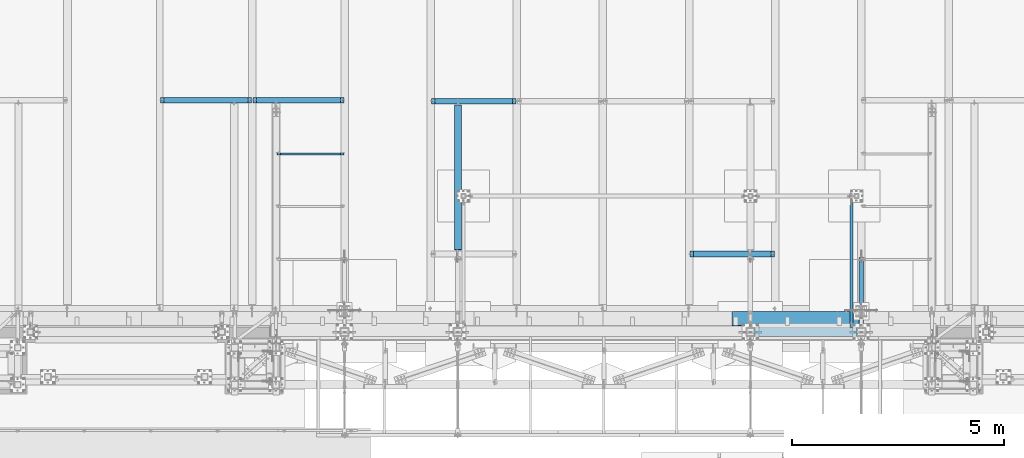
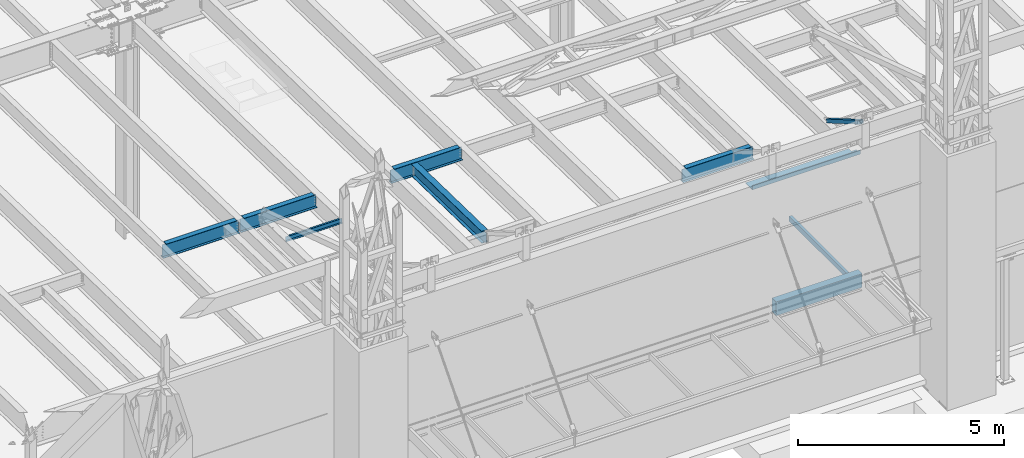
# One storey, part 1058 of 1763: 9 beams, 1 member, 10 elements without a shape of their own.
"""IFC2X3 building model written with IfcOpenShell, lengths in millimetres."""

from ifc_helpers import new_model, si_unit, frame, origin_with_axes, place, context, subcontext, project, spatial, faceted_brep, material, type_object, element, aggregate, save


model = new_model("IFC2X3")

# Units and contexts
model_context = context("Model", 3, precision=1e-05, world=origin_with_axes())
body_context = subcontext(model_context, "Body", "Model", "MODEL_VIEW")
ifc_project = project(units=[si_unit("LENGTHUNIT", "METRE", prefix="MILLI"), si_unit("AREAUNIT", "SQUARE_METRE"), si_unit("VOLUMEUNIT", "CUBIC_METRE"), si_unit("MASSUNIT", "GRAM", prefix="KILO"), si_unit("TIMEUNIT", "SECOND"), si_unit("PLANEANGLEUNIT", "RADIAN"), si_unit("SOLIDANGLEUNIT", "STERADIAN"), si_unit("THERMODYNAMICTEMPERATUREUNIT", "DEGREE_CELSIUS"), si_unit("LUMINOUSINTENSITYUNIT", "LUMEN")], contexts=[model_context])

# Site, building, storey
site_placement = place(None, origin_with_axes())
site = spatial("IfcSite", under=ifc_project, at=site_placement, CompositionType="ELEMENT")
building_placement = place(site_placement, origin_with_axes())
building = spatial("IfcBuilding", under=site, at=building_placement, Name="Undefined", CompositionType="ELEMENT")
storey_placement = place(building_placement, origin_with_axes())
storey = spatial("IfcBuildingStorey", under=building, at=storey_placement, Name="Undefined", CompositionType="ELEMENT", Elevation=0.0)

# Assembly, beam
assembly_1_placement = place(storey_placement, origin_with_axes())
assembly_1 = element("IfcElementAssembly", 1, at=assembly_1_placement, inside=storey, Name="CHANNEL", AssemblyPlace="NOTDEFINED", PredefinedType="RIGID_FRAME")
ifc_material_1 = material(Name="STEEL/A36")
beam_type_1 = type_object("IfcBeamType", Name="C6X8.2", PredefinedType="NOTDEFINED")
beam_1_placement = place(assembly_1_placement, frame((-63211.0608225783, -10007.1940204662, 12050.4660879227), z_axis=(0.0, 0.0, 1.0), x_axis=(1.0, 0.0, 0.0)))
beam_1 = element("IfcBeam", 2, at=beam_1_placement, type_object=beam_type_1, material=ifc_material_1, Name="CHANNEL", ObjectType="C6X8.2", context=body_context, shape_type="Brep", body=[
    faceted_brep([(94.4562501907349, 19.0499999999993, 50.7999999979074), (94.4562501907349, 23.8125, 50.7999999979074), (18.2562500000058, 23.8125, 50.7999999979074), (18.2562500000058, 19.0499999999993, 50.7999999979074), (99.3163297087813, 19.0499999999993, 51.766729920495), (99.3163297087813, 23.8125, 51.766729920495), (103.436506176935, 19.0499999999993, 54.5197438209725), (103.436506176935, 23.8125, 54.5197438209725), (106.189520077409, 19.0499999999993, 58.6399202891262), (106.189520077409, 23.8125, 58.6399202891262), (107.15625, 19.0499999999993, 63.4999998071726), (107.15625, 23.8125, 63.4999998071726), (107.15625, -23.8125, 76.2000000000007), (107.15625, 23.8125, 76.2000000000007), (107.15625, 19.0499999999993, 65.0887700000003), (107.15625, -23.8125, 72.2296624999999), (18.2562500000058, 19.0499999999993, -65.0887700000003), (18.2562500000058, -23.8125, -72.2296624999999), (1599.16104887993, -23.8125, -72.2296624999999), (1599.16104887993, 19.0499999999993, -65.0887700000003), (18.2562500000058, -23.8125, -76.2000000000007), (1599.16104887993, -23.8125, -76.2000000000007), (18.2562500000058, 23.8125, -76.2000000000007), (1599.16104887993, 23.8125, -76.2000000000007), (1599.16104887993, 23.8125, 50.8000000015836), (1599.16104887993, 19.0499999999993, 50.8000000015836), (1529.31104868917, 23.8125, 50.8000000015836), (1529.31104868917, 19.0499999999993, 50.8000000015836), (1524.45096917113, 23.8125, 51.7667299241712), (1524.45096917113, 19.0499999999993, 51.7667299241712), (1520.33079270297, 23.8125, 54.5197438246487), (1520.33079270297, 19.0499999999993, 54.5197438246487), (1517.5777788025, 23.8125, 58.6399202928023), (1517.5777788025, 19.0499999999993, 58.6399202928023), (1516.61104887991, 23.8125, 63.4999998108487), (1516.61104887991, 19.0499999999993, 63.4999998108487), (1516.61104887991, -23.8125, 76.2000000000007), (1516.61104887991, -23.8125, 72.2296624999999), (1516.61104887991, 19.0499999999993, 65.0887700000003), (1516.61104887991, 23.8125, 76.2000000000007)], [[[0, 1, 2, 3]], [[4, 5, 1, 0]], [[6, 7, 5, 4]], [[8, 9, 7, 6]], [[10, 11, 9, 8]], [[12, 13, 11, 10, 14, 15]], [[16, 17, 18, 19]], [[17, 20, 21, 18]], [[20, 22, 23, 21]], [[19, 18, 21, 23, 24, 25]], [[25, 24, 26, 27]], [[27, 26, 28, 29]], [[29, 28, 30, 31]], [[31, 30, 32, 33]], [[33, 32, 34, 35]], [[36, 37, 38, 35, 34, 39]], [[37, 36, 12, 15]], [[38, 37, 15, 14]], [[8, 6, 4, 0, 3, 16, 19, 25, 27, 29, 31, 33, 35, 38, 14, 10]], [[22, 20, 17, 16, 3, 2]], [[39, 34, 32, 30, 28, 26, 24, 23, 22, 2, 1, 5, 7, 9, 11, 13]], [[36, 39, 13, 12]]]),
])
aggregate(assembly_1, [beam_1])

assembly_2_placement = place(storey_placement, origin_with_axes())
assembly_2 = element("IfcElementAssembly", 3, at=assembly_2_placement, inside=storey, Name="BEAM", AssemblyPlace="NOTDEFINED", PredefinedType="RIGID_FRAME")
ifc_material_2 = material()
beam_type_2 = type_object("IfcBeamType", Name="HSS16X8X1/4", PredefinedType="NOTDEFINED")
beam_2_placement = place(assembly_2_placement, frame((-51917.027008321, -14208.1275869816, 8636.0), z_axis=(0.0, 0.0, 1.0), x_axis=(1.0, 0.0, 0.0)))
beam_2 = element("IfcBeam", 4, at=beam_2_placement, type_object=beam_type_2, material=ifc_material_2, Name="BEAM", ObjectType="HSS16X8X1/4", context=body_context, shape_type="Brep", body=[
    faceted_brep([(0.0, 95.25, -196.85), (0.0, -95.25, -196.85), (2413.00000000001, -95.25, -196.85), (2413.00000000001, 95.25, -196.85), (0.0, -95.25, 196.85), (2413.00000000001, -95.25, 196.85), (0.0, 95.25, 196.85), (2413.00000000001, 95.25, 196.85), (0.0, 101.600000000006, -203.2), (0.0, 101.600000000006, 203.2), (2413.00000000001, 101.6, 203.200000000001), (2413.00000000001, 101.6, -203.200000000001), (0.0, -101.600000000006, 203.2), (2413.00000000001, -101.6, 203.200000000001), (0.0, -101.600000000006, -203.2), (2413.00000000001, -101.6, -203.200000000001)], [[[0, 1, 2, 3]], [[1, 4, 5, 2]], [[4, 6, 7, 5]], [[6, 0, 3, 7]], [[8, 9, 10, 11]], [[9, 12, 13, 10]], [[12, 14, 15, 13]], [[14, 8, 11, 15]], [[13, 15, 11, 10], [5, 7, 3, 2]], [[14, 12, 9, 8], [6, 4, 1, 0]]]),
])
aggregate(assembly_2, [beam_2])

assembly_3_placement = place(storey_placement, origin_with_axes())
assembly_3 = element("IfcElementAssembly", 5, at=assembly_3_placement, inside=storey, Name="BEAM", AssemblyPlace="NOTDEFINED", PredefinedType="RIGID_FRAME")
ifc_material_3 = material(Name="STEEL/A992")
beam_type_3 = type_object("IfcBeamType", Name="W14X30", PredefinedType="NOTDEFINED")
beam_3_placement = place(assembly_3_placement, frame((-58917.9122752341, -12375.797568249, 12000.4308275564), z_axis=(0.0, 0.0209013539966291, 0.999781542838788), x_axis=(0.0, 0.999781542776098, -0.0209013569953182)))
beam_3 = element("IfcBeam", 6, at=beam_3_placement, type_object=beam_type_3, material=ifc_material_3, Name="BEAM", ObjectType="W14X30", context=body_context, shape_type="Brep", body=[
    faceted_brep([(3499.73692840905, -3.17500000000291, -166.687500001286), (3499.73692840905, -85.7249999999985, -166.687500001286), (3499.73692840905, -85.7249999999985, -176.212500001295), (3499.73692840905, 85.7249999999985, -176.212500001295), (3499.73692840905, 85.7249999999985, -166.687500001286), (3499.73692840905, 3.17500000000291, -166.687500001286), (3499.73692840906, 3.17500000000291, -163.51249981689), (3499.73692840906, -3.17500000000291, -163.51249981689), (3500.70365833165, 3.17500000000291, -158.652420298831), (3500.70365833165, -3.17500000000291, -158.652420298831), (3503.45667223214, 3.17500000000291, -154.532243830672), (3503.45667223214, -3.17500000000291, -154.532243830672), (3507.5768487003, 3.17500000000291, -151.779229930187), (3507.5768487003, -3.17500000000291, -151.779229930187), (3512.43692821836, 3.17500000000291, -150.812500007598), (3512.43692821836, -3.17500000000291, -150.812500007598), (3600.80591795297, -3.17500000000291, -150.812500007625), (3600.80591795297, 3.17500000000291, -150.812500007625), (111.128437087651, 3.17500000000291, 166.687500000098), (111.128437087651, 85.7249999999985, 166.687500000098), (3525.13692840938, 85.7249999999985, 166.687499998974), (3525.13692840938, 3.17500000000291, 166.687499998974), (111.128437087542, -3.17500000000291, -163.512499809849), (111.128437087542, 3.17500000000291, -163.512499809849), (111.12843708754, 3.17500000000291, -166.687500000171), (111.12843708754, 85.7249999999985, -166.687500000171), (111.128437087536, 85.7249999999985, -176.212500000178), (111.128437087536, -85.7249999999985, -176.212500000178), (111.12843708754, -85.7249999999985, -166.687500000171), (111.12843708754, -3.17500000000291, -166.687500000171), (110.161707164953, -3.17500000000291, -158.65242029179), (110.161707164953, 3.17500000000291, -158.65242029179), (107.408693264468, -3.17500000000291, -154.532243823627), (107.408693264468, 3.17500000000291, -154.532243823627), (103.288516796305, -3.17500000000291, -151.779229923141), (103.288516796305, 3.17500000000291, -151.779229923141), (98.4284372782495, -3.17500000000291, -150.812500000549), (98.4284372782495, 3.17500000000291, -150.812500000549), (22.7151965710145, -3.17500000000291, -150.812500000524), (22.7151965710145, 3.17500000000291, -150.812500000524), (16.40944753248, -3.17500000000291, 150.812500000327), (16.40944753248, 3.17500000000291, 150.812500000327), (98.4284372783495, -3.17500000000291, 150.8125000003), (98.4284372783495, 3.17500000000291, 150.8125000003), (103.288516796405, -3.17500000000291, 151.779229922889), (103.288516796405, 3.17500000000291, 151.779229922889), (107.408693264571, -3.17500000000291, 154.532243823371), (107.408693264571, 3.17500000000291, 154.532243823371), (110.161707165056, -3.17500000000291, 158.652420291533), (110.161707165056, 3.17500000000291, 158.652420291533), (111.128437087647, -3.17500000000291, 163.512499809589), (111.128437087647, 3.17500000000291, 163.512499809589), (111.128437087651, -85.7249999999985, 176.212500000105), (111.128437087651, 85.7249999999985, 176.212500000105), (111.128437087651, -3.17500000000291, 166.687500000098), (111.128437087651, -85.7249999999985, 166.687500000098), (3525.13692840938, -3.17500000000291, 166.687499998974), (3525.13692840938, -85.7249999999985, 166.687499998974), (3525.13692840938, -85.7249999999985, 176.212499998981), (3525.13692840938, 85.7249999999985, 176.212499998981), (3525.13692840938, -3.17500000000291, 163.512499802697), (3525.13692840938, 3.17500000000291, 163.512499802697), (3526.10365833196, -3.17500000000291, 158.652420284639), (3526.10365833196, 3.17500000000291, 158.652420284639), (3528.85667223244, -3.17500000000291, 154.532243816475), (3528.85667223244, 3.17500000000291, 154.532243816475), (3532.97684870061, -3.17500000000291, 151.77922991599), (3532.97684870061, 3.17500000000291, 151.77922991599), (3537.83692821866, -3.17500000000291, 150.812499993397), (3537.83692821866, 3.17500000000291, 150.812499993397), (3594.50016891443, -3.17500000000291, 150.812499993381), (3594.50016891443, 3.17500000000291, 150.812499993381)], [[[0, 1, 2, 3, 4, 5, 6, 7]], [[7, 6, 8, 9]], [[9, 8, 10, 11]], [[11, 10, 12, 13]], [[13, 12, 14, 15]], [[16, 15, 14, 17]], [[18, 19, 20, 21]], [[22, 23, 24, 25, 26, 27, 28, 29]], [[30, 31, 23, 22]], [[32, 33, 31, 30]], [[34, 35, 33, 32]], [[36, 37, 35, 34]], [[38, 39, 37, 36]], [[40, 41, 39, 38]], [[42, 43, 41, 40]], [[44, 45, 43, 42]], [[46, 47, 45, 44]], [[48, 49, 47, 46]], [[50, 51, 49, 48]], [[52, 53, 19, 18, 51, 50, 54, 55]], [[55, 54, 56, 57]], [[52, 55, 57, 58]], [[53, 52, 58, 59]], [[19, 53, 59, 20]], [[58, 57, 56, 60, 61, 21, 20, 59]], [[62, 63, 61, 60]], [[64, 65, 63, 62]], [[66, 67, 65, 64]], [[68, 69, 67, 66]], [[70, 71, 69, 68]], [[71, 70, 16, 17]], [[12, 10, 8, 6, 5, 24, 23, 31, 33, 35, 37, 39, 41, 43, 45, 47, 49, 51, 18, 21, 61, 63, 65, 67, 69, 71, 17, 14]], [[25, 24, 5, 4]], [[26, 25, 4, 3]], [[27, 26, 3, 2]], [[28, 27, 2, 1]], [[29, 28, 1, 0]], [[70, 68, 66, 64, 62, 60, 56, 54, 50, 48, 46, 44, 42, 40, 38, 36, 34, 32, 30, 22, 29, 0, 7, 9, 11, 13, 15, 16]]]),
])
aggregate(assembly_3, [beam_3])

assembly_4_placement = place(storey_placement, origin_with_axes())
assembly_4 = element("IfcElementAssembly", 7, at=assembly_4_placement, inside=storey, Name="BEAM", AssemblyPlace="NOTDEFINED", PredefinedType="RIGID_FRAME")
beam_type_4 = type_object("IfcBeamType", Name="W16X26", PredefinedType="NOTDEFINED")
beam_4_placement = place(assembly_4_placement, frame((-59562.4372736983, -8763.05542596541, 11901.1291231283), z_axis=(0.0, 0.0, 1.0), x_axis=(1.0, 0.0, 0.0)))
beam_4 = element("IfcBeam", 8, at=beam_4_placement, type_object=beam_type_4, material=ifc_material_3, Name="BEAM", ObjectType="W16X26", context=body_context, shape_type="Brep", body=[
    faceted_brep([(87.312500190732, -3.17499999999927, 161.665001675578), (87.312500190732, 3.17499999999927, 161.665001675578), (17.4624999999942, 3.17499999999927, 161.665001675578), (17.4624999999942, -3.17499999999927, 161.665001675578), (92.1725797087784, -3.17499999999927, 162.631731598165), (92.1725797087784, 3.17499999999927, 162.631731598165), (96.292756176932, -3.17499999999927, 165.384745498643), (96.292756176932, 3.17499999999927, 165.384745498643), (97.1527139056197, -3.17499999999927, 166.671763191049), (97.1527139056197, 3.17499999999927, 166.671763191049), (17.4625000000087, -3.17499999999927, -190.5), (17.4625000000087, -69.8500000000004, -190.5), (2014.53750000001, -69.8500000000004, -190.5), (2014.53750000001, -3.17499999999927, -190.5), (17.4625000000087, -69.8500000000004, -200.025), (2014.53750000001, -69.8500000000004, -200.025), (17.4625000000087, 69.8500000000004, -200.025), (2014.53750000001, 69.8500000000004, -200.025), (17.4625000000087, 69.8500000000004, -190.5), (2014.53750000001, 69.8500000000004, -190.5), (17.4625000000087, 3.17499999999927, -190.5), (2014.53750000001, 3.17499999999927, -190.5), (2014.53750000001, 3.17499999999927, 161.665001678701), (2014.53750000001, -3.17499999999927, 161.665001678701), (1944.68749980927, 3.17499999999927, 161.665001678701), (1944.68749980927, -3.17499999999927, 161.665001678701), (1939.82742029122, 3.17499999999927, 162.631731601288), (1939.82742029122, -3.17499999999927, 162.631731601288), (1935.70724382307, 3.17499999999927, 165.384745501766), (1935.70724382307, -3.17499999999927, 165.384745501766), (1934.84728609816, 3.17499999999927, 166.671763188517), (1934.84728609816, -3.17499999999927, 166.671763188517), (1934.11974687481, 3.17499999999927, 167.157889355802), (1934.11974687481, -3.17499999999927, 167.157889355802), (1931.36673297434, 3.17499999999927, 171.278065823955), (1931.36673297434, -3.17499999999927, 171.278065823955), (1930.40000305175, 3.17499999999927, 176.138145342002), (1930.40000305175, -3.17499999999927, 176.138145342002), (101.599996948236, 3.17499999999927, 190.5), (101.599996948236, 69.8500000000004, 190.5), (1930.40000305175, 69.8500000000004, 190.5), (1930.40000305175, 3.17499999999927, 190.5), (101.599996948236, -69.8500000000004, 200.025), (101.599996948236, -69.8500000000004, 190.5), (1930.40000305175, -69.8500000000004, 190.5), (1930.40000305175, -69.8500000000004, 200.025), (101.599996948236, 69.8500000000004, 200.025), (1930.40000305175, 69.8500000000004, 200.025), (1930.40000305175, -3.17499999999927, 190.5), (101.599996948236, -3.17499999999927, 190.5), (101.599996948236, 3.17499999999927, 176.138145342), (101.599996948236, -3.17499999999927, 176.138145342), (100.633267025645, 3.17499999999927, 171.278065823954), (100.633267025645, -3.17499999999927, 171.278065823954), (97.8802531251713, 3.17499999999927, 167.1578893558), (97.8802531251713, -3.17499999999927, 167.1578893558)], [[[0, 1, 2, 3]], [[4, 5, 1, 0]], [[6, 7, 5, 4]], [[8, 9, 7, 6]], [[10, 11, 12, 13]], [[11, 14, 15, 12]], [[14, 16, 17, 15]], [[16, 18, 19, 17]], [[18, 20, 21, 19]], [[13, 12, 15, 17, 19, 21, 22, 23]], [[23, 22, 24, 25]], [[25, 24, 26, 27]], [[27, 26, 28, 29]], [[29, 28, 30, 31]], [[32, 33, 31, 30]], [[33, 32, 34, 35]], [[35, 34, 36, 37]], [[38, 39, 40, 41]], [[42, 43, 44, 45]], [[46, 42, 45, 47]], [[39, 46, 47, 40]], [[45, 44, 48, 37, 36, 41, 40, 47]], [[43, 49, 48, 44]], [[42, 46, 39, 38, 50, 51, 49, 43]], [[51, 50, 52, 53]], [[53, 52, 54, 55]], [[4, 0, 3, 10, 13, 23, 25, 27, 29, 31, 33, 35, 37, 48, 49, 51, 53, 55, 8, 6]], [[20, 18, 16, 14, 11, 10, 3, 2]], [[54, 52, 50, 38, 41, 36, 34, 32, 30, 28, 26, 24, 22, 21, 20, 2, 1, 5, 7, 9]], [[55, 54, 9, 8]]]),
])
aggregate(assembly_4, [beam_4])

assembly_5_placement = place(storey_placement, origin_with_axes())
assembly_5 = element("IfcElementAssembly", 9, at=assembly_5_placement, inside=storey, Name="BEAM", AssemblyPlace="NOTDEFINED", PredefinedType="RIGID_FRAME")
beam_5_placement = place(assembly_5_placement, frame((-53466.4372736983, -12372.1144876504, 11976.5798333454), z_axis=(0.0, 0.0, 1.0), x_axis=(1.0, 0.0, 0.0)))
beam_5 = element("IfcBeam", 10, at=beam_5_placement, type_object=beam_type_4, material=ifc_material_3, Name="BEAM", ObjectType="W16X26", context=body_context, shape_type="Brep", body=[
    faceted_brep([(87.312500190732, -3.17499999999927, 161.665001675578), (87.312500190732, 3.17499999999927, 161.665001675578), (17.4624999999942, 3.17499999999927, 161.665001675578), (17.4624999999942, -3.17499999999927, 161.665001675578), (92.1725797087784, -3.17499999999927, 162.631731598165), (92.1725797087784, 3.17499999999927, 162.631731598165), (96.292756176932, -3.17499999999927, 165.384745498643), (96.292756176932, 3.17499999999927, 165.384745498643), (97.1527139056197, -3.17499999999927, 166.671763191049), (97.1527139056197, 3.17499999999927, 166.671763191049), (17.4625000000087, -3.17499999999927, -190.5), (17.4625000000087, -69.8500000000004, -190.5), (2014.53750000001, -69.8500000000004, -190.5), (2014.53750000001, -3.17499999999927, -190.5), (17.4625000000087, -69.8500000000004, -200.025), (2014.53750000001, -69.8500000000004, -200.025), (17.4625000000087, 69.8500000000004, -200.025), (2014.53750000001, 69.8500000000004, -200.025), (17.4625000000087, 69.8500000000004, -190.5), (2014.53750000001, 69.8500000000004, -190.5), (17.4625000000087, 3.17499999999927, -190.5), (2014.53750000001, 3.17499999999927, -190.5), (2014.53750000001, 3.17499999999927, 161.665001678701), (2014.53750000001, -3.17499999999927, 161.665001678701), (1944.68749980927, 3.17499999999927, 161.665001678701), (1944.68749980927, -3.17499999999927, 161.665001678701), (1939.82742029122, 3.17499999999927, 162.631731601288), (1939.82742029122, -3.17499999999927, 162.631731601288), (1935.70724382307, 3.17499999999927, 165.384745501766), (1935.70724382307, -3.17499999999927, 165.384745501766), (1934.84728609816, 3.17499999999927, 166.671763188517), (1934.84728609816, -3.17499999999927, 166.671763188517), (1934.11974687481, 3.17499999999927, 167.157889355802), (1934.11974687481, -3.17499999999927, 167.157889355802), (1931.36673297434, 3.17499999999927, 171.278065823955), (1931.36673297434, -3.17499999999927, 171.278065823955), (1930.40000305175, 3.17499999999927, 176.138145342002), (1930.40000305175, -3.17499999999927, 176.138145342002), (101.599996948236, 3.17499999999927, 190.5), (101.599996948236, 69.8500000000004, 190.5), (1930.40000305175, 69.8500000000004, 190.5), (1930.40000305175, 3.17499999999927, 190.5), (101.599996948236, -69.8500000000004, 200.025), (101.599996948236, -69.8500000000004, 190.5), (1930.40000305175, -69.8500000000004, 190.5), (1930.40000305175, -69.8500000000004, 200.025), (101.599996948236, 69.8500000000004, 200.025), (1930.40000305175, 69.8500000000004, 200.025), (1930.40000305175, -3.17499999999927, 190.5), (101.599996948236, -3.17499999999927, 190.5), (101.599996948236, 3.17499999999927, 176.138145342), (101.599996948236, -3.17499999999927, 176.138145342), (100.633267025645, 3.17499999999927, 171.278065823954), (100.633267025645, -3.17499999999927, 171.278065823954), (97.8802531251713, 3.17499999999927, 167.1578893558), (97.8802531251713, -3.17499999999927, 167.1578893558)], [[[0, 1, 2, 3]], [[4, 5, 1, 0]], [[6, 7, 5, 4]], [[8, 9, 7, 6]], [[10, 11, 12, 13]], [[11, 14, 15, 12]], [[14, 16, 17, 15]], [[16, 18, 19, 17]], [[18, 20, 21, 19]], [[13, 12, 15, 17, 19, 21, 22, 23]], [[23, 22, 24, 25]], [[25, 24, 26, 27]], [[27, 26, 28, 29]], [[29, 28, 30, 31]], [[32, 33, 31, 30]], [[33, 32, 34, 35]], [[35, 34, 36, 37]], [[38, 39, 40, 41]], [[42, 43, 44, 45]], [[46, 42, 45, 47]], [[39, 46, 47, 40]], [[45, 44, 48, 37, 36, 41, 40, 47]], [[43, 49, 48, 44]], [[42, 46, 39, 38, 50, 51, 49, 43]], [[51, 50, 52, 53]], [[53, 52, 54, 55]], [[4, 0, 3, 10, 13, 23, 25, 27, 29, 31, 33, 35, 37, 48, 49, 51, 53, 55, 8, 6]], [[20, 18, 16, 14, 11, 10, 3, 2]], [[54, 52, 50, 38, 41, 36, 34, 32, 30, 28, 26, 24, 22, 21, 20, 2, 1, 5, 7, 9]], [[55, 54, 9, 8]]]),
])
aggregate(assembly_5, [beam_5])

assembly_6_placement = place(storey_placement, origin_with_axes())
assembly_6 = element("IfcElementAssembly", 11, at=assembly_6_placement, inside=storey, Name="BEAM", AssemblyPlace="NOTDEFINED", PredefinedType="RIGID_FRAME")
beam_6_placement = place(assembly_6_placement, frame((-63773.7572736983, -8739.17542108259, 11900.629892136), z_axis=(0.0, 0.0, 1.0), x_axis=(1.0, 0.0, 0.0)))
beam_6 = element("IfcBeam", 12, at=beam_6_placement, type_object=beam_type_4, material=ifc_material_3, Name="BEAM", ObjectType="W16X26", context=body_context, shape_type="Brep", body=[
    faceted_brep([(2079.3075, -69.8500000000004, 200.025), (2079.3075, -69.8500000000004, 190.5), (2079.3075, -3.17499999999927, 190.5), (2079.3075, -3.17499999999927, 180.715001487702), (2079.3075, 3.17499999999927, 180.715001487702), (2079.3075, 3.17499999999927, 190.5), (2079.3075, 69.8500000000004, 190.5), (2079.3075, 69.8500000000004, 200.025), (2080.27422992259, -3.17499999999927, 175.854921969656), (2080.27422992259, 3.17499999999927, 175.854921969656), (2083.02724382306, -3.17499999999927, 171.734745501502), (2083.02724382306, 3.17499999999927, 171.734745501502), (2087.14742029121, -3.17499999999927, 168.981731601025), (2087.14742029121, 3.17499999999927, 168.981731601025), (2092.00749980926, -3.17499999999927, 168.015001678437), (2092.00749980926, 3.17499999999927, 168.015001678437), (2161.8575, -3.17499999999927, 168.015001678437), (2161.8575, 3.17499999999927, 168.015001678437), (100.012500000012, -69.8500000000004, 200.025), (100.012500000012, 69.8500000000004, 200.025), (100.012500000012, 69.8500000000004, 190.5), (100.012500000012, 3.17499999999927, 190.5), (100.012500000012, 3.17499999999927, 180.715001488035), (100.012500000012, -3.17499999999927, 180.715001488035), (100.012500000012, -3.17499999999927, 190.5), (100.012500000012, -69.8500000000004, 190.5), (99.0457700774205, 3.17499999999927, 175.854921969989), (99.0457700774205, -3.17499999999927, 175.854921969989), (96.2927561769466, 3.17499999999927, 171.734745501835), (96.2927561769466, -3.17499999999927, 171.734745501835), (92.1725797087929, 3.17499999999927, 168.981731601358), (92.1725797087929, -3.17499999999927, 168.981731601358), (87.3125001907465, 3.17499999999927, 168.01500167877), (87.3125001907465, -3.17499999999927, 168.01500167877), (17.4625000000087, 3.17499999999927, 168.01500167877), (17.4625000000087, -3.17499999999927, 168.01500167877), (17.4625000000087, 3.17499999999927, -190.5), (17.4625000000087, 69.8500000000004, -190.5), (17.4625000000087, 69.8500000000004, -200.025), (17.4625000000087, -69.8500000000004, -200.025), (17.4625000000087, -69.8500000000004, -190.5), (17.4625000000087, -3.17499999999927, -190.5), (2161.8575, 3.17499999999927, -190.5), (2161.8575, 69.8500000000004, -190.5), (2161.8575, 69.8500000000004, -200.025), (2161.8575, -69.8500000000004, -200.025), (2161.8575, -69.8500000000004, -190.5), (2161.8575, -3.17499999999927, -190.5)], [[[0, 1, 2, 3, 4, 5, 6, 7]], [[8, 9, 4, 3]], [[10, 11, 9, 8]], [[12, 13, 11, 10]], [[14, 15, 13, 12]], [[16, 17, 15, 14]], [[18, 19, 20, 21, 22, 23, 24, 25]], [[23, 22, 26, 27]], [[27, 26, 28, 29]], [[29, 28, 30, 31]], [[31, 30, 32, 33]], [[33, 32, 34, 35]], [[36, 37, 38, 39, 40, 41, 35, 34]], [[37, 36, 42, 43]], [[38, 37, 43, 44]], [[39, 38, 44, 45]], [[40, 39, 45, 46]], [[41, 40, 46, 47]], [[12, 10, 8, 3, 2, 24, 23, 27, 29, 31, 33, 35, 41, 47, 16, 14]], [[25, 24, 2, 1]], [[18, 25, 1, 0]], [[19, 18, 0, 7]], [[20, 19, 7, 6]], [[21, 20, 6, 5]], [[42, 36, 34, 32, 30, 28, 26, 22, 21, 5, 4, 9, 11, 13, 15, 17]], [[47, 46, 45, 44, 43, 42, 17, 16]]]),
])
aggregate(assembly_6, [beam_6])

assembly_7_placement = place(storey_placement, origin_with_axes())
assembly_7 = element("IfcElementAssembly", 13, at=assembly_7_placement, inside=storey, Name="BEAM", AssemblyPlace="NOTDEFINED", PredefinedType="RIGID_FRAME")
beam_7_placement = place(assembly_7_placement, frame((-65953.0772736983, -8739.17542108259, 11900.629892136), z_axis=(0.0, 0.0, 1.0), x_axis=(1.0, 0.0, 0.0)))
beam_7 = element("IfcBeam", 14, at=beam_7_placement, type_object=beam_type_4, material=ifc_material_3, Name="BEAM", ObjectType="W16X26", context=body_context, shape_type="Brep", body=[
    faceted_brep([(2079.3075, -69.8500000000004, 200.025), (2079.3075, -69.8500000000004, 190.5), (2079.3075, -3.17499999999927, 190.5), (2079.3075, -3.17499999999927, 180.715001487702), (2079.3075, 3.17499999999927, 180.715001487702), (2079.3075, 3.17499999999927, 190.5), (2079.3075, 69.8500000000004, 190.5), (2079.3075, 69.8500000000004, 200.025), (2080.27422992259, -3.17499999999927, 175.854921969656), (2080.27422992259, 3.17499999999927, 175.854921969656), (2083.02724382306, -3.17499999999927, 171.734745501502), (2083.02724382306, 3.17499999999927, 171.734745501502), (2087.14742029121, -3.17499999999927, 168.981731601025), (2087.14742029121, 3.17499999999927, 168.981731601025), (2092.00749980926, -3.17499999999927, 168.015001678437), (2092.00749980926, 3.17499999999927, 168.015001678437), (2161.8575, -3.17499999999927, 168.015001678437), (2161.8575, 3.17499999999927, 168.015001678437), (99.21875, -69.8500000000004, 200.025), (99.21875, 69.8500000000004, 200.025), (99.21875, 69.8500000000004, 190.5), (99.21875, 3.17499999999927, 190.5), (99.21875, 3.17499999999927, 180.715001487531), (99.21875, -3.17499999999927, 180.715001487531), (99.21875, -3.17499999999927, 190.5), (99.21875, -69.8500000000004, 190.5), (98.2520200774161, 3.17499999999927, 175.854921969485), (98.2520200774161, -3.17499999999927, 175.854921969485), (95.4990061769349, 3.17499999999927, 171.734745501331), (95.4990061769349, -3.17499999999927, 171.734745501331), (91.378829708774, 3.17499999999927, 168.981731600854), (91.378829708774, -3.17499999999927, 168.981731600854), (86.5187501907349, 3.17499999999927, 168.015001678266), (86.5187501907349, -3.17499999999927, 168.015001678266), (16.6687499999971, 3.17499999999927, 168.015001678266), (16.6687499999971, -3.17499999999927, 168.015001678266), (16.6687499999971, 3.17499999999927, -190.5), (16.6687499999971, 69.8500000000004, -190.5), (16.6687499999971, 69.8500000000004, -200.025), (16.6687499999971, -69.8500000000004, -200.025), (16.6687499999971, -69.8500000000004, -190.5), (16.6687499999971, -3.17499999999927, -190.5), (2161.8575, 3.17499999999927, -190.5), (2161.8575, 69.8500000000004, -190.5), (2161.8575, 69.8500000000004, -200.025), (2161.8575, -69.8500000000004, -200.025), (2161.8575, -69.8500000000004, -190.5), (2161.8575, -3.17499999999927, -190.5)], [[[0, 1, 2, 3, 4, 5, 6, 7]], [[8, 9, 4, 3]], [[10, 11, 9, 8]], [[12, 13, 11, 10]], [[14, 15, 13, 12]], [[16, 17, 15, 14]], [[18, 19, 20, 21, 22, 23, 24, 25]], [[23, 22, 26, 27]], [[27, 26, 28, 29]], [[29, 28, 30, 31]], [[31, 30, 32, 33]], [[33, 32, 34, 35]], [[36, 37, 38, 39, 40, 41, 35, 34]], [[37, 36, 42, 43]], [[38, 37, 43, 44]], [[39, 38, 44, 45]], [[40, 39, 45, 46]], [[41, 40, 46, 47]], [[12, 10, 8, 3, 2, 24, 23, 27, 29, 31, 33, 35, 41, 47, 16, 14]], [[25, 24, 2, 1]], [[18, 25, 1, 0]], [[19, 18, 0, 7]], [[20, 19, 7, 6]], [[21, 20, 6, 5]], [[42, 36, 34, 32, 30, 28, 26, 22, 21, 5, 4, 9, 11, 13, 15, 17]], [[47, 46, 45, 44, 43, 42, 17, 16]]]),
])
aggregate(assembly_7, [beam_7])

# Assembly, member
assembly_8_placement = place(storey_placement, origin_with_axes())
assembly_8 = element("IfcElementAssembly", 15, at=assembly_8_placement, inside=storey, Name="V. BRACE", AssemblyPlace="NOTDEFINED", PredefinedType="RIGID_FRAME")
member_type = type_object("IfcMemberType", Name="HSS4X4X3/8", PredefinedType="NOTDEFINED")
member_placement = place(assembly_8_placement, frame((-49402.4372736983, -14106.5252982712, 13182.6000019665), z_axis=(0.0, 0.50173172990702, 0.865023277839683), x_axis=(0.0, 0.865023198927323, -0.501731865957846)))
member = element("IfcMember", 16, at=member_placement, type_object=member_type, material=ifc_material_2, Name="V. BRACE", ObjectType="HSS4X4X3/8", context=body_context, shape_type="Brep", body=[
    faceted_brep([(1886.82133111547, 7.93799800872512, 50.8000000000629), (1804.27132806142, 7.93799800872512, 50.8000000000575), (1804.27132806142, 7.93799800872512, 41.2750000000651), (1886.82133111547, 7.93799800872512, 41.2750000000688), (1804.27132806142, -7.93700008392625, 50.8000000000575), (1804.27132806142, -7.93700008392625, 41.2750000000651), (1886.82133111301, -7.93700008392625, 50.8000000000629), (1886.82133111547, -7.93700008392625, 41.2750000000688), (1886.82133111547, 7.93799800872512, -41.2749999998769), (1804.27132806142, 7.93799800872512, -41.2749999998814), (1804.27132806142, 7.93799800872512, -50.7999999998738), (1886.82133111547, 7.93799800872512, -50.7999999998719), (1804.27132806142, -7.93700008392625, -41.2749999998814), (1804.27132806142, -7.93700008392625, -50.7999999998738), (1886.82133111302, -7.93700008392625, -41.2749999998759), (1886.82133111547, -7.93700008392625, -50.7999999998719), (-23.943093575228, 41.2750000000015, 41.2749999999705), (23.9376633641841, 41.2750000000015, -41.2749999999724), (1886.82133111547, 41.2750000000015, -41.2749999998769), (1886.82133111547, 41.2750000000015, 41.2750000000688), (1886.82133111547, -41.2750000000015, 41.2750000000688), (-23.943093575228, -41.2750000000015, 41.2749999999705), (23.9376633641841, -41.2750000000015, -41.2749999999724), (1886.82133111547, -41.2750000000015, -41.2749999998769), (29.4623660879624, -50.8000000000029, -50.7999999999665), (-29.4677962990063, -50.8000000000029, 50.7999999999647), (-29.4677962990063, 50.8000000000029, 50.7999999999647), (29.4623660879624, 50.8000000000029, -50.7999999999665), (1886.82133111547, 50.8000000000029, 50.8000000000629), (1886.82133111547, 50.8000000000029, -50.7999999998719), (1886.82133111547, -50.8000000000029, -50.7999999998719), (1886.82133111547, -50.8000000000029, 50.8000000000629)], [[[0, 1, 2, 3]], [[4, 5, 2, 1]], [[6, 7, 5, 4]], [[8, 9, 10, 11]], [[12, 13, 10, 9]], [[14, 15, 13, 12]], [[16, 17, 18, 19]], [[20, 21, 16, 19, 3, 2, 5, 7]], [[22, 21, 20, 23]], [[9, 8, 18, 17, 22, 23, 14, 12]], [[24, 25, 26, 27], [16, 21, 22, 17]], [[27, 26, 28, 29]], [[19, 18, 8, 11, 29, 28, 0, 3]], [[30, 24, 27, 29, 11, 10, 13, 15]], [[25, 24, 30, 31]], [[1, 0, 28, 26, 25, 31, 6, 4]], [[31, 30, 15, 14, 23, 20, 7, 6]]]),
])
aggregate(assembly_8, [member])

# Assembly, beam
assembly_9_placement = place(storey_placement, origin_with_axes())
assembly_9 = element("IfcElementAssembly", 17, at=assembly_9_placement, inside=storey, Name="BEAM", AssemblyPlace="NOTDEFINED", PredefinedType="RIGID_FRAME")
beam_type_5 = type_object("IfcBeamType", PredefinedType="NOTDEFINED")
beam_8_placement = place(assembly_9_placement, frame((-50926.4372736984, -13728.6998186171, 12207.875), z_axis=(-1.0, 0.0, 0.0), x_axis=(0.0, -1.0, 0.0)))
beam_8 = element("IfcBeam", 18, at=beam_8_placement, type_object=beam_type_5, material=ifc_material_1, Name="BENT_PLATE", context=body_context, shape_type="Brep", body=[
    faceted_brep([(127.000180053701, -3.17499999999927, -1384.30000610353), (127.000180053701, 3.17499999999927, -1384.30000610353), (127.000180053701, 3.17499999999927, -1520.825), (127.000180053701, -3.17499999999927, -1520.825), (0.0, -3.17499999999927, -1384.30000610353), (0.0, 3.17499999999927, -1384.30000610353), (330.200016784669, 3.17499999999927, 1520.825), (0.0, 3.17499999999927, 1520.825), (0.0, -3.17499999999927, 1520.825), (336.550018310547, -3.17499999999927, 1520.825), (336.549987792969, 123.825000000001, 1520.825), (330.19998779297, 123.824998474123, 1520.825), (330.200016784669, 3.17499999999927, -1520.825), (330.19998779297, 123.824998474123, -1520.825), (336.549987792969, 123.825000000001, -1520.825), (336.550018310547, -3.17499999999927, -1520.825)], [[[0, 1, 2, 3]], [[4, 5, 1, 0]], [[6, 7, 8, 9, 10, 11]], [[12, 6, 11, 13]], [[10, 14, 13, 11]], [[9, 15, 14, 10]], [[12, 13, 14, 15, 3, 2]], [[7, 6, 12, 2, 1, 5]], [[8, 7, 5, 4]], [[15, 9, 8, 4, 0, 3]]]),
])
aggregate(assembly_9, [beam_8])

assembly_10_placement = place(storey_placement, origin_with_axes())
assembly_10 = element("IfcElementAssembly", 19, at=assembly_10_placement, inside=storey, Name="BEAM", AssemblyPlace="NOTDEFINED", PredefinedType="RIGID_FRAME")
beam_type_6 = type_object("IfcBeamType", Name="HSS6X3X3/16", PredefinedType="NOTDEFINED")
beam_9_placement = place(assembly_10_placement, frame((-49632.6587034872, -14106.5275625533, 8547.1), z_axis=(0.0, 0.0, 1.0), x_axis=(0.0, 1.0, 0.0)))
beam_9 = element("IfcBeam", 20, at=beam_9_placement, type_object=beam_type_6, material=ifc_material_2, Name="BEAM", ObjectType="HSS6X3X3/16", context=body_context, shape_type="Brep", body=[
    faceted_brep([(1.20053300634027e-10, 33.3375000000015, -71.4375), (-1.21872290037572e-10, -33.3375000000015, -71.4375), (3055.94005206906, -33.3374999902444, -71.4375), (3055.9400520693, 33.3375000097585, -71.4375), (-1.21872290037572e-10, -33.3375000000015, 71.4375), (3055.94005206906, -33.3374999902444, 71.4375), (1.20053300634027e-10, 33.3375000000015, 71.4375), (3055.9400520693, 33.3375000097585, 71.4375), (1.38243194669485e-10, 38.0999999999985, -76.2000000000007), (1.38243194669485e-10, 38.0999999999985, 76.2000000000007), (3055.94005206932, 38.1000000097556, 76.2000000000007), (3055.94005206932, 38.1000000097556, -76.2000000000007), (-1.40062184073031e-10, -38.0999999999985, 76.2000000000007), (3055.94005206904, -38.0999999902415, 76.2000000000007), (-1.40062184073031e-10, -38.0999999999985, -76.2000000000007), (3055.94005206904, -38.0999999902415, -76.2000000000007)], [[[0, 1, 2, 3]], [[1, 4, 5, 2]], [[4, 6, 7, 5]], [[6, 0, 3, 7]], [[8, 9, 10, 11]], [[9, 12, 13, 10]], [[12, 14, 15, 13]], [[14, 8, 11, 15]], [[13, 15, 11, 10], [5, 7, 3, 2]], [[14, 12, 9, 8], [6, 4, 1, 0]]]),
])
aggregate(assembly_10, [beam_9])

save(model, "model.ifc")
